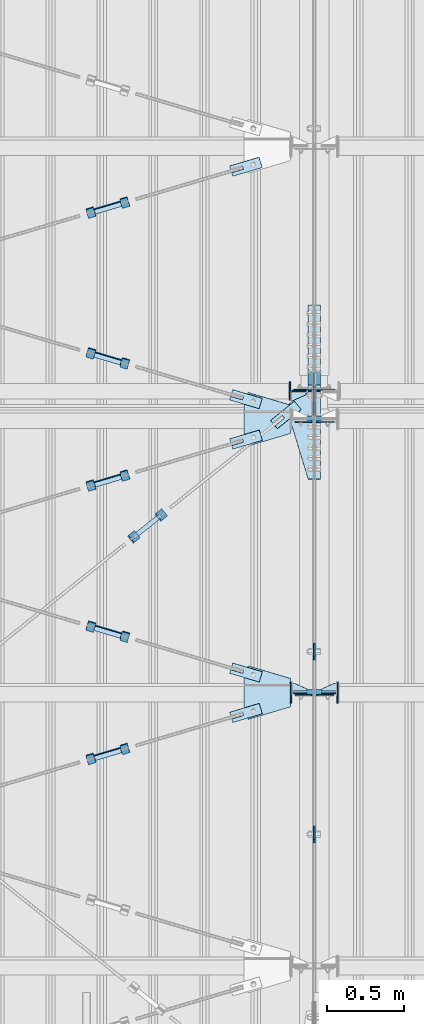
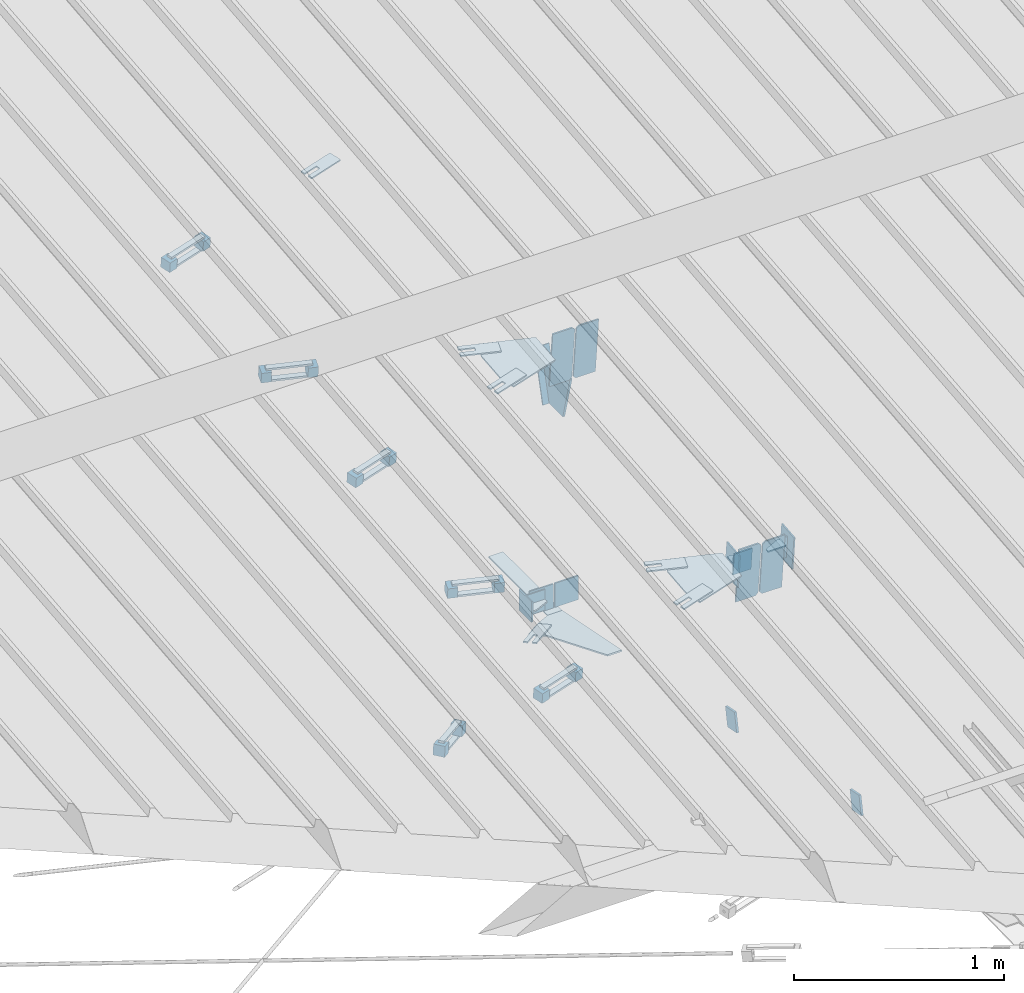
# One storey, part 113 of 709: 53 plates, 5 openings, 20 elements without a shape of their own.
"""IFC4 building model written with IfcOpenShell, lengths in millimetres."""

from ifc_helpers import new_model, si_unit, direction, frame, origin_with_axes, place, context, subcontext, project, spatial, line, indexed_curve, outline, extrude, material, element, aggregate, save


model = new_model("IFC4")

# Units and contexts
model_context = context("Model", 3, precision=0.2, world=origin_with_axes(), true_north=direction((0.0, 1.0)))
body_context = subcontext(model_context, "Body", "Model", "MODEL_VIEW")
ifc_project = project(units=[si_unit("LENGTHUNIT", "METRE", prefix="MILLI"), si_unit("AREAUNIT", "SQUARE_METRE"), si_unit("VOLUMEUNIT", "CUBIC_METRE"), si_unit("MASSUNIT", "GRAM", prefix="KILO"), si_unit("TIMEUNIT", "SECOND"), si_unit("PLANEANGLEUNIT", "RADIAN"), si_unit("SOLIDANGLEUNIT", "STERADIAN"), si_unit("THERMODYNAMICTEMPERATUREUNIT", "DEGREE_CELSIUS"), si_unit("LUMINOUSINTENSITYUNIT", "LUMEN")], contexts=[model_context])

# Site, building, storey
site_placement = place(None, origin_with_axes())
site = spatial("IfcSite", under=ifc_project, at=site_placement, CompositionType="ELEMENT")
building_placement = place(site_placement, origin_with_axes())
building = spatial("IfcBuilding", under=site, at=building_placement, Name="Undefined", CompositionType="ELEMENT")
storey_placement = place(building_placement, origin_with_axes())
storey = spatial("IfcBuildingStorey", under=building, at=storey_placement, Name="Undefined", CompositionType="ELEMENT", Elevation=0.0)

# Assembly, plates
assembly_1_placement = place(storey_placement, frame((10000.0, 346.0, 7089.70002), z_axis=(1.0, 0.0, 0.0), x_axis=(0.0, 0.9950371902, 0.099503719)))
assembly_1 = element("IfcElementAssembly", 1, at=assembly_1_placement, inside=storey)
ifc_material_1 = material(Name="C355-6", Category="STEEL")
plate_1_placement = place(assembly_1_placement, frame((5220.02987, -437.93487, 0.0), z_axis=(0.0, 0.0, -1.0), x_axis=(-0.1614213634, 0.9868855777, 0.0)))
plate_1 = element("IfcPlate", 2, at=plate_1_placement, material=ifc_material_1, ObjectType="442", context=body_context, shape_type="SolidModel", body=[
    extrude(outline(indexed_curve([(0.0, 0.0), (270.19115, 0.0), (225.20717, 275.01958), (-33.64648, 125.57036)], segments=[line(1, 2, 3, 4, 1)])), frame((0.0, 0.0, 6.0), z_axis=(0.0, 0.0, 1.0), x_axis=(1.0, 0.0, 0.0)), (0.0, 0.0, -1.0), 12.0),
])
plate_2_placement = place(assembly_1_placement, frame((5458.83099, -172.70172, -40.0), z_axis=(-0.9353786626, 0.3536477874, 0.0), x_axis=(-0.3536477874, -0.9353786626, 0.0)))
plate_2 = element("IfcPlate", 3, at=plate_2_placement, material=ifc_material_1, ObjectType="443", context=body_context, shape_type="SolidModel", body=[
    extrude(outline(indexed_curve([(0.0, 0.0), (298.89845, 0.0), (298.89845, 80.0), (0.0, 80.0)], segments=[line(1, 2, 3, 4, 1)])), frame((0.0, 0.0, 4.0), z_axis=(0.0, 0.0, 1.0), x_axis=(1.0, 0.0, 0.0)), (0.0, 0.0, -1.0), 8.0),
])
plate_3_placement = place(assembly_1_placement, frame((5169.0059, 163.0, -127.0), z_axis=(1.0, 0.0, 0.0), x_axis=(0.0, 0.0, 1.0)))
plate_3 = element("IfcPlate", 4, at=plate_3_placement, material=ifc_material_1, ObjectType="585", context=body_context, shape_type="SolidModel", body=[
    extrude(outline(indexed_curve([(0.0, 0.0), (108.0, 0.0), (123.0, 15.0), (123.0, 311.0), (108.0, 326.0), (0.0, 326.0)], segments=[line(1, 2, 3, 4, 5, 6, 1)])), frame((0.0, 0.0, 4.0), z_axis=(0.0, 0.0, 1.0), x_axis=(1.0, 0.0, 0.0)), (0.0, 0.0, -1.0), 8.0),
])
plate_4_placement = place(assembly_1_placement, frame((3383.44474, 163.0, 127.0), z_axis=(-1.0, 0.0, 0.0), x_axis=(0.0, 0.0, -1.0)))
plate_4 = element("IfcPlate", 5, at=plate_4_placement, material=ifc_material_1, ObjectType="585", context=body_context, shape_type="SolidModel", body=[
    extrude(outline(indexed_curve([(0.0, 0.0), (108.0, 0.0), (123.0, 15.0), (123.0, 311.0), (108.0, 326.0), (0.0, 326.0)], segments=[line(1, 2, 3, 4, 5, 6, 1)])), frame((0.0, 0.0, 4.0), z_axis=(0.0, 0.0, 1.0), x_axis=(1.0, 0.0, 0.0)), (0.0, 0.0, -1.0), 8.0),
])
plate_5_placement = place(assembly_1_placement, frame((3383.44474, 163.0, -127.0), z_axis=(1.0, 0.0, 0.0), x_axis=(0.0, 0.0, 1.0)))
plate_5 = element("IfcPlate", 6, at=plate_5_placement, material=ifc_material_1, ObjectType="585", context=body_context, shape_type="SolidModel", body=[
    extrude(outline(indexed_curve([(0.0, 0.0), (108.0, 0.0), (123.0, 15.0), (123.0, 311.0), (108.0, 326.0), (0.0, 326.0)], segments=[line(1, 2, 3, 4, 5, 6, 1)])), frame((0.0, 0.0, 4.0), z_axis=(0.0, 0.0, 1.0), x_axis=(1.0, 0.0, 0.0)), (0.0, 0.0, -1.0), 8.0),
])
plate_6_placement = place(assembly_1_placement, frame((5169.0059, 163.0, 127.0), z_axis=(-1.0, 0.0, 0.0), x_axis=(0.0, 0.0, -1.0)))
plate_6 = element("IfcPlate", 7, at=plate_6_placement, material=ifc_material_1, ObjectType="585", context=body_context, shape_type="SolidModel", body=[
    extrude(outline(indexed_curve([(0.0, 0.0), (108.0, 0.0), (123.0, 15.0), (123.0, 311.0), (108.0, 326.0), (0.0, 326.0)], segments=[line(1, 2, 3, 4, 5, 6, 1)])), frame((0.0, 0.0, 4.0), z_axis=(0.0, 0.0, 1.0), x_axis=(1.0, 0.0, 0.0)), (0.0, 0.0, -1.0), 8.0),
])
aggregate(assembly_1, [plate_1, plate_2, plate_3, plate_4, plate_5, plate_6])

# Assembly, plate
assembly_2_placement = place(storey_placement, frame((8916.07962, 4796.2353, 6158.55487), z_axis=(0.625451877, -0.7802627439, 1e-10), x_axis=(0.7742288439, 0.6206151549, -0.124123031)))
assembly_2 = element("IfcElementAssembly", 8, at=assembly_2_placement, inside=storey)
plate_7_placement = place(assembly_2_placement, frame((1061.42526, -5.35577, -34.5878), z_axis=(0.0, -0.9882227647, 0.1530221141), x_axis=(1.0, 0.0, 0.0)))
plate_7 = element("IfcPlate", 9, at=plate_7_placement, material=ifc_material_1, ObjectType="488", context=body_context, shape_type="SolidModel", body=[
    extrude(outline(indexed_curve([(0.0, 0.0), (200.0, 0.0), (200.0, 70.0), (0.0, 70.0), (0.0, 46.0), (80.0, 46.0), (80.0, 24.0), (0.0, 24.0)], segments=[line(1, 2, 3, 4, 5, 6, 7, 8, 1)])), frame((0.0, 0.0, 4.0), z_axis=(0.0, 0.0, 1.0), x_axis=(1.0, 0.0, 0.0)), (0.0, 0.0, -1.0), 8.0),
])
aggregate(assembly_2, [plate_7])

# Assembly, plates
assembly_3_placement = place(storey_placement, frame((9026.78495, 4846.52715, 6174.04872), z_axis=(-0.7742288439, -0.6206151548, 0.1241230313), x_axis=(-0.625451877, 0.780262744, 0.0)))
assembly_3 = element("IfcElementAssembly", 10, at=assembly_3_placement, inside=storey)
ifc_material_2 = material(Name="Steel_Undefined", Category="STEEL")
plate_8_placement = place(assembly_3_placement, frame((15.0, -6.0, 230.0), z_axis=(0.0, 1.0, 0.0), x_axis=(1.0, 0.0, 0.0)))
plate_8 = element("IfcPlate", 11, at=plate_8_placement, material=ifc_material_2, ObjectType="484", context=body_context, shape_type="SolidModel", body=[
    extrude(outline(indexed_curve([(0.0, 0.0), (30.0, 0.0), (30.0, 230.0), (0.0, 230.0)], segments=[line(1, 2, 3, 4, 1)])), frame((0.0, 0.0, 6.0), z_axis=(0.0, 0.0, 1.0), x_axis=(1.0, 0.0, 0.0)), (0.0, 0.0, -1.0), 12.0),
])
plate_9_placement = place(assembly_3_placement, frame((15.0, 66.0, 230.0), z_axis=(0.0, 1.0, 0.0), x_axis=(1.0, 0.0, 0.0)))
plate_9 = element("IfcPlate", 12, at=plate_9_placement, material=ifc_material_2, ObjectType="484", context=body_context, shape_type="SolidModel", body=[
    extrude(outline(indexed_curve([(0.0, 0.0), (30.0, 0.0), (30.0, 230.0), (0.0, 230.0)], segments=[line(1, 2, 3, 4, 1)])), frame((0.0, 0.0, 6.0), z_axis=(0.0, 0.0, 1.0), x_axis=(1.0, 0.0, 0.0)), (0.0, 0.0, -1.0), 12.0),
])
plate_10_placement = place(assembly_3_placement, frame((0.0, 0.0, 230.0), z_axis=(0.0, 0.0, 1.0), x_axis=(1.0, 0.0, 0.0)))
plate_10 = element("IfcPlate", 13, at=plate_10_placement, material=ifc_material_2, ObjectType="483", context=body_context, shape_type="SolidModel", body=[
    extrude(outline(indexed_curve([(0.0, 0.0), (60.0, 0.0), (60.0, 60.0), (0.0, 60.0)], segments=[line(1, 2, 3, 4, 1)])), frame((0.0, 0.0, 25.0), z_axis=(0.0, 0.0, 1.0), x_axis=(1.0, 0.0, 0.0)), (0.0, 0.0, -1.0), 50.0),
])
plate_11_placement = place(assembly_3_placement, origin_with_axes())
plate_11 = element("IfcPlate", 14, at=plate_11_placement, material=ifc_material_2, ObjectType="482", context=body_context, shape_type="SolidModel", body=[
    extrude(outline(indexed_curve([(0.0, 0.0), (60.0, 0.0), (60.0, 60.0), (0.0, 60.0)], segments=[line(1, 2, 3, 4, 1)])), frame((0.0, 0.0, 25.0), z_axis=(0.0, 0.0, 1.0), x_axis=(1.0, 0.0, 0.0)), (0.0, 0.0, -1.0), 50.0),
])
aggregate(assembly_3, [plate_8, plate_9, plate_10, plate_11])

assembly_4_placement = place(storey_placement, frame((10000.0, 5668.61344, 5980.00002), z_axis=(1.0, 0.0, 0.0), x_axis=(0.0, 1.0, 0.0)))
assembly_4 = element("IfcElementAssembly", 15, at=assembly_4_placement, inside=storey)
plate_12_placement = place(assembly_4_placement, frame((12.38656, 164.3, 134.0), z_axis=(-1.0, 0.0, 0.0), x_axis=(0.0, 0.0, -1.0)))
plate_12 = element("IfcPlate", 16, at=plate_12_placement, material=ifc_material_1, ObjectType="558", context=body_context, shape_type="SolidModel", body=[
    extrude(outline(indexed_curve([(0.0, 0.0), (130.0, 0.0), (130.0, 140.0), (0.0, 140.0)], segments=[line(1, 2, 3, 4, 1)])), frame((0.0, 0.0, 4.0), z_axis=(0.0, 0.0, 1.0), x_axis=(1.0, 0.0, 0.0)), (0.0, 0.0, -1.0), 8.0),
])
plate_13_placement = place(assembly_4_placement, frame((12.38656, 164.3, -134.0), z_axis=(1.0, 0.0, 0.0), x_axis=(0.0, 0.0, 1.0)))
plate_13 = element("IfcPlate", 17, at=plate_13_placement, material=ifc_material_1, ObjectType="558", context=body_context, shape_type="SolidModel", body=[
    extrude(outline(indexed_curve([(0.0, 0.0), (130.0, 0.0), (130.0, 140.0), (0.0, 140.0)], segments=[line(1, 2, 3, 4, 1)])), frame((0.0, 0.0, 4.0), z_axis=(0.0, 0.0, 1.0), x_axis=(1.0, 0.0, 0.0)), (0.0, 0.0, -1.0), 8.0),
])
plate_14_placement = place(assembly_4_placement, frame((-0.78446, -3.92232, 40.0), z_axis=(0.1961161349, 0.9805806757, 0.0), x_axis=(0.0, 0.0, -1.0)))
plate_14 = element("IfcPlate", 18, at=plate_14_placement, material=ifc_material_1, ObjectType="487", context=body_context, shape_type="SolidModel", body=[
    extrude(outline(indexed_curve([(0.0, 0.0), (80.0, 0.0), (175.76932, 57.25102), (253.1922, 120.5416), (196.23068, 190.22219), (80.0, 579.50696), (0.0, 579.50696)], segments=[line(1, 2, 3, 4, 5, 6, 7, 1)])), frame((0.0, 0.0, 4.0), z_axis=(0.0, 0.0, 1.0), x_axis=(1.0, 0.0, 0.0)), (0.0, 0.0, -1.0), 8.0),
])
plate_15_placement = place(assembly_4_placement, frame((564.38656, -4.0, -40.0), z_axis=(0.0, 1.0, 0.0), x_axis=(-1.0, 0.0, 0.0)))
plate_15 = element("IfcPlate", 19, at=plate_15_placement, material=ifc_material_1, ObjectType="446", context=body_context, shape_type="SolidModel", body=[
    extrude(outline(indexed_curve([(0.0, 0.0), (564.38656, 0.0), (564.38656, 80.0), (0.0, 80.0)], segments=[line(1, 2, 3, 4, 1)])), frame((0.0, 0.0, 4.0), z_axis=(0.0, 0.0, 1.0), x_axis=(1.0, 0.0, 0.0)), (0.0, 0.0, -1.0), 8.0),
])
aggregate(assembly_4, [plate_12, plate_13, plate_14, plate_15])

# Assembly, plate
assembly_5_placement = place(storey_placement, frame((10000.0, 2758.46612, 6684.40595), z_axis=(-1.0, 0.0, 0.0), x_axis=(0.0, 0.9805806757, -0.1961161349)))
assembly_5 = element("IfcElementAssembly", 20, at=assembly_5_placement, inside=storey)
plate_16_placement = place(assembly_5_placement, origin_with_axes())
plate_16 = element("IfcPlate", 21, at=plate_16_placement, material=ifc_material_1, ObjectType="491", context=body_context, shape_type="SolidModel", body=[
    extrude(outline(indexed_curve([(0.0, 0.0), (90.0, 0.0), (90.0, 110.0), (0.0, 110.0)], segments=[line(1, 2, 3, 4, 1)])), frame((0.0, 0.0, 6.0), z_axis=(0.0, 0.0, 1.0), x_axis=(1.0, 0.0, 0.0)), (0.0, 0.0, -1.0), 12.0),
])
aggregate(assembly_5, [plate_16])

assembly_6_placement = place(storey_placement, frame((10000.0, 3946.08299, 6446.88258), z_axis=(-1.0, 0.0, 0.0), x_axis=(0.0, 0.9805806757, -0.1961161349)))
assembly_6 = element("IfcElementAssembly", 22, at=assembly_6_placement, inside=storey)
plate_17_placement = place(assembly_6_placement, origin_with_axes())
plate_17 = element("IfcPlate", 23, at=plate_17_placement, material=ifc_material_1, ObjectType="491", context=body_context, shape_type="SolidModel", body=[
    extrude(outline(indexed_curve([(0.0, 0.0), (90.0, 0.0), (90.0, 110.0), (0.0, 110.0)], segments=[line(1, 2, 3, 4, 1)])), frame((0.0, 0.0, 6.0), z_axis=(0.0, 0.0, 1.0), x_axis=(1.0, 0.0, 0.0)), (0.0, 0.0, -1.0), 12.0),
])
aggregate(assembly_6, [plate_17])

# Assembly, plates
assembly_7_placement = place(storey_placement, frame((4000.0, 5673.0, 6074.30002), z_axis=(0.0, -1.0, 0.0), x_axis=(1.0, 0.0, 0.0)))
assembly_7 = element("IfcElementAssembly", 24, at=assembly_7_placement, inside=storey)
plate_18_placement = place(assembly_7_placement, frame((5946.0, 0.0, 60.0), z_axis=(0.0, 1.0, 0.0), x_axis=(0.0, 0.0, -1.0)))
plate_18 = element("IfcPlate", 25, at=plate_18_placement, material=ifc_material_1, ObjectType="561", context=body_context, shape_type="SolidModel", body=[
    extrude(outline(indexed_curve([(0.0, 80.0), (36.0, 0.0), (56.0, 0.0), (56.0, 90.0), (46.0, 100.0), (0.0, 100.0)], segments=[line(1, 2, 3, 4, 5, 6, 1)])), frame((0.0, 0.0, 4.0), z_axis=(0.0, 0.0, 1.0), x_axis=(1.0, 0.0, 0.0)), (0.0, 0.0, -1.0), 8.0),
])
plate_19_placement = place(assembly_7_placement, frame((5842.0, 60.0, -60.0), z_axis=(1.0, 0.0, 0.0), x_axis=(0.0, 0.0, 1.0)))
plate_19 = element("IfcPlate", 26, at=plate_19_placement, material=ifc_material_1, ObjectType="559", context=body_context, shape_type="SolidModel", body=[
    extrude(outline(indexed_curve([(0.0, 0.0), (120.0, 0.0), (120.0, 120.0), (0.0, 120.0)], segments=[line(1, 2, 3, 4, 1)])), frame((0.0, 0.0, 4.0), z_axis=(0.0, 0.0, 1.0), x_axis=(1.0, 0.0, 0.0)), (0.0, 0.0, -1.0), 8.0),
])
plate_20_placement = place(assembly_7_placement, frame((5946.0, 60.0, 0.0), z_axis=(0.0, 0.0, -1.0), x_axis=(0.0, -1.0, 0.0)))
plate_20 = element("IfcPlate", 27, at=plate_20_placement, material=ifc_material_1, ObjectType="560", context=body_context, shape_type="SolidModel", body=[
    extrude(outline(indexed_curve([(0.0, 0.0), (120.0, 0.0), (120.0, 100.0), (0.0, 100.0)], segments=[line(1, 2, 3, 4, 1)])), frame((0.0, 0.0, 4.0), z_axis=(0.0, 0.0, 1.0), x_axis=(1.0, 0.0, 0.0)), (0.0, 0.0, -1.0), 8.0),
])
aggregate(assembly_7, [plate_18, plate_19, plate_20])

# Assembly, plate, voiding feature
assembly_8_placement = place(storey_placement, frame((8658.15773, 3315.21204, 7468.02522), z_axis=(0.2852311229, -0.9537021177, -0.0953702118), x_axis=(0.9584587662, 0.2838155751, 0.028381558)))
assembly_8 = element("IfcElementAssembly", 28, at=assembly_8_placement, inside=storey)
plate_21_placement = place(assembly_8_placement, frame((1036.9749, 0.0, 35.0), z_axis=(0.0, 1.0, 0.0), x_axis=(0.0, 0.0, -1.0)))
plate_21 = element("IfcPlate", 29, at=plate_21_placement, material=ifc_material_1, ObjectType="574", context=body_context, shape_type="SolidModel", body=[
    extrude(outline(indexed_curve([(0.0, 0.0), (70.0, 0.0), (70.0, 200.0), (0.0, 200.0)], segments=[line(1, 2, 3, 4, 1)])), frame((0.0, 0.0, 4.0), z_axis=(0.0, 0.0, 1.0), x_axis=(1.0, 0.0, 0.0)), (0.0, 0.0, -1.0), 8.0),
])
voiding_feature_1_placement = place(plate_21_placement, frame((24.0, 120.0, 0.0), z_axis=(0.0, 0.0, 1.0), x_axis=(1.0, 0.0, 0.0)))
element("IfcVoidingFeature", 30, at=voiding_feature_1_placement, cuts=plate_21, Name="PLATE", PredefinedType="HOLE", context=body_context, shape_type="SolidModel", body=[
    extrude(outline(indexed_curve([(0.0, 0.0), (22.0, 0.0), (22.0, 85.0), (0.0, 85.0)], segments=[line(1, 2, 3, 4, 1)])), frame((0.0, 0.0, 6.5), z_axis=(0.0, 0.0, 1.0), x_axis=(1.0, 0.0, 0.0)), (0.0, 0.0, -1.0), 13.0),
])
aggregate(assembly_8, [plate_21])

# Assembly, plates
assembly_9_placement = place(storey_placement, frame((8776.93742, 3316.25466, 7498.27911), z_axis=(-0.9584587662, -0.2838155751, -0.0283815575), x_axis=(-0.2852311229, 0.9537021176, 0.095370212)))
assembly_9 = element("IfcElementAssembly", 31, at=assembly_9_placement, inside=storey)
plate_22_placement = place(assembly_9_placement, frame((15.0, 66.0, 230.0), z_axis=(0.0, 1.0, 0.0), x_axis=(1.0, 0.0, 0.0)))
plate_22 = element("IfcPlate", 32, at=plate_22_placement, material=ifc_material_2, ObjectType="484", context=body_context, shape_type="SolidModel", body=[
    extrude(outline(indexed_curve([(0.0, 0.0), (30.0, 0.0), (30.0, 230.0), (0.0, 230.0)], segments=[line(1, 2, 3, 4, 1)])), frame((0.0, 0.0, 6.0), z_axis=(0.0, 0.0, 1.0), x_axis=(1.0, 0.0, 0.0)), (0.0, 0.0, -1.0), 12.0),
])
plate_23_placement = place(assembly_9_placement, frame((0.0, 0.0, 230.0), z_axis=(0.0, 0.0, 1.0), x_axis=(1.0, 0.0, 0.0)))
plate_23 = element("IfcPlate", 33, at=plate_23_placement, material=ifc_material_2, ObjectType="483", context=body_context, shape_type="SolidModel", body=[
    extrude(outline(indexed_curve([(0.0, 0.0), (60.0, 0.0), (60.0, 60.0), (0.0, 60.0)], segments=[line(1, 2, 3, 4, 1)])), frame((0.0, 0.0, 25.0), z_axis=(0.0, 0.0, 1.0), x_axis=(1.0, 0.0, 0.0)), (0.0, 0.0, -1.0), 50.0),
])
plate_24_placement = place(assembly_9_placement, frame((15.0, -6.0, 230.0), z_axis=(0.0, 1.0, 0.0), x_axis=(1.0, 0.0, 0.0)))
plate_24 = element("IfcPlate", 34, at=plate_24_placement, material=ifc_material_2, ObjectType="484", context=body_context, shape_type="SolidModel", body=[
    extrude(outline(indexed_curve([(0.0, 0.0), (30.0, 0.0), (30.0, 230.0), (0.0, 230.0)], segments=[line(1, 2, 3, 4, 1)])), frame((0.0, 0.0, 6.0), z_axis=(0.0, 0.0, 1.0), x_axis=(1.0, 0.0, 0.0)), (0.0, 0.0, -1.0), 12.0),
])
plate_25_placement = place(assembly_9_placement, origin_with_axes())
plate_25 = element("IfcPlate", 35, at=plate_25_placement, material=ifc_material_2, ObjectType="482", context=body_context, shape_type="SolidModel", body=[
    extrude(outline(indexed_curve([(0.0, 0.0), (60.0, 0.0), (60.0, 60.0), (0.0, 60.0)], segments=[line(1, 2, 3, 4, 1)])), frame((0.0, 0.0, 25.0), z_axis=(0.0, 0.0, 1.0), x_axis=(1.0, 0.0, 0.0)), (0.0, 0.0, -1.0), 50.0),
])
aggregate(assembly_9, [plate_22, plate_23, plate_24, plate_25])

# Assembly, plate, voiding feature
assembly_10_placement = place(storey_placement, frame((8658.15773, 5091.91179, 7645.6952), z_axis=(0.2852311229, -0.9537021177, -0.0953702118), x_axis=(0.9584587662, 0.2838155751, 0.028381558)))
assembly_10 = element("IfcElementAssembly", 36, at=assembly_10_placement, inside=storey)
plate_26_placement = place(assembly_10_placement, frame((1036.9749, 0.0, 35.0), z_axis=(0.0, 1.0, 0.0), x_axis=(0.0, 0.0, -1.0)))
plate_26 = element("IfcPlate", 37, at=plate_26_placement, material=ifc_material_1, ObjectType="574", context=body_context, shape_type="SolidModel", body=[
    extrude(outline(indexed_curve([(0.0, 0.0), (70.0, 0.0), (70.0, 200.0), (0.0, 200.0)], segments=[line(1, 2, 3, 4, 1)])), frame((0.0, 0.0, 4.0), z_axis=(0.0, 0.0, 1.0), x_axis=(1.0, 0.0, 0.0)), (0.0, 0.0, -1.0), 8.0),
])
voiding_feature_2_placement = place(plate_26_placement, frame((24.0, 120.0, 0.0), z_axis=(0.0, 0.0, 1.0), x_axis=(1.0, 0.0, 0.0)))
element("IfcVoidingFeature", 38, at=voiding_feature_2_placement, cuts=plate_26, Name="PLATE", PredefinedType="HOLE", context=body_context, shape_type="SolidModel", body=[
    extrude(outline(indexed_curve([(0.0, 0.0), (22.0, 0.0), (22.0, 85.0), (0.0, 85.0)], segments=[line(1, 2, 3, 4, 1)])), frame((0.0, 0.0, 6.5), z_axis=(0.0, 0.0, 1.0), x_axis=(1.0, 0.0, 0.0)), (0.0, 0.0, -1.0), 13.0),
])
aggregate(assembly_10, [plate_26])

# Assembly, plates
assembly_11_placement = place(storey_placement, frame((8776.93742, 5092.95441, 7675.94908), z_axis=(-0.9584587662, -0.2838155751, -0.0283815575), x_axis=(-0.2852311229, 0.9537021176, 0.095370212)))
assembly_11 = element("IfcElementAssembly", 39, at=assembly_11_placement, inside=storey)
plate_27_placement = place(assembly_11_placement, origin_with_axes())
plate_27 = element("IfcPlate", 40, at=plate_27_placement, material=ifc_material_2, ObjectType="482", context=body_context, shape_type="SolidModel", body=[
    extrude(outline(indexed_curve([(0.0, 0.0), (60.0, 0.0), (60.0, 60.0), (0.0, 60.0)], segments=[line(1, 2, 3, 4, 1)])), frame((0.0, 0.0, 25.0), z_axis=(0.0, 0.0, 1.0), x_axis=(1.0, 0.0, 0.0)), (0.0, 0.0, -1.0), 50.0),
])
plate_28_placement = place(assembly_11_placement, frame((15.0, 66.0, 230.0), z_axis=(0.0, 1.0, 0.0), x_axis=(1.0, 0.0, 0.0)))
plate_28 = element("IfcPlate", 41, at=plate_28_placement, material=ifc_material_2, ObjectType="484", context=body_context, shape_type="SolidModel", body=[
    extrude(outline(indexed_curve([(0.0, 0.0), (30.0, 0.0), (30.0, 230.0), (0.0, 230.0)], segments=[line(1, 2, 3, 4, 1)])), frame((0.0, 0.0, 6.0), z_axis=(0.0, 0.0, 1.0), x_axis=(1.0, 0.0, 0.0)), (0.0, 0.0, -1.0), 12.0),
])
plate_29_placement = place(assembly_11_placement, frame((15.0, -6.0, 230.0), z_axis=(0.0, 1.0, 0.0), x_axis=(1.0, 0.0, 0.0)))
plate_29 = element("IfcPlate", 42, at=plate_29_placement, material=ifc_material_2, ObjectType="484", context=body_context, shape_type="SolidModel", body=[
    extrude(outline(indexed_curve([(0.0, 0.0), (30.0, 0.0), (30.0, 230.0), (0.0, 230.0)], segments=[line(1, 2, 3, 4, 1)])), frame((0.0, 0.0, 6.0), z_axis=(0.0, 0.0, 1.0), x_axis=(1.0, 0.0, 0.0)), (0.0, 0.0, -1.0), 12.0),
])
plate_30_placement = place(assembly_11_placement, frame((0.0, 0.0, 230.0), z_axis=(0.0, 0.0, 1.0), x_axis=(1.0, 0.0, 0.0)))
plate_30 = element("IfcPlate", 43, at=plate_30_placement, material=ifc_material_2, ObjectType="483", context=body_context, shape_type="SolidModel", body=[
    extrude(outline(indexed_curve([(0.0, 0.0), (60.0, 0.0), (60.0, 60.0), (0.0, 60.0)], segments=[line(1, 2, 3, 4, 1)])), frame((0.0, 0.0, 25.0), z_axis=(0.0, 0.0, 1.0), x_axis=(1.0, 0.0, 0.0)), (0.0, 0.0, -1.0), 50.0),
])
aggregate(assembly_11, [plate_27, plate_28, plate_29, plate_30])

# Assembly, plate, voiding feature
assembly_12_placement = place(storey_placement, frame((8658.15773, 4109.89565, 7547.49358), z_axis=(-0.2852311229, -0.9537021177, -0.0953702118), x_axis=(0.9584587662, -0.2838155751, -0.028381558)))
assembly_12 = element("IfcElementAssembly", 44, at=assembly_12_placement, inside=storey)
plate_31_placement = place(assembly_12_placement, frame((1036.9749, 0.0, 35.0), z_axis=(0.0, 1.0, 0.0), x_axis=(0.0, 0.0, -1.0)))
plate_31 = element("IfcPlate", 45, at=plate_31_placement, material=ifc_material_1, ObjectType="574", context=body_context, shape_type="SolidModel", body=[
    extrude(outline(indexed_curve([(0.0, 0.0), (70.0, 0.0), (70.0, 200.0), (0.0, 200.0)], segments=[line(1, 2, 3, 4, 1)])), frame((0.0, 0.0, 4.0), z_axis=(0.0, 0.0, 1.0), x_axis=(1.0, 0.0, 0.0)), (0.0, 0.0, -1.0), 8.0),
])
voiding_feature_3_placement = place(plate_31_placement, frame((24.0, 120.0, 0.0), z_axis=(0.0, 0.0, 1.0), x_axis=(1.0, 0.0, 0.0)))
element("IfcVoidingFeature", 46, at=voiding_feature_3_placement, cuts=plate_31, Name="PLATE", PredefinedType="HOLE", context=body_context, shape_type="SolidModel", body=[
    extrude(outline(indexed_curve([(0.0, 0.0), (22.0, 0.0), (22.0, 85.0), (0.0, 85.0)], segments=[line(1, 2, 3, 4, 1)])), frame((0.0, 0.0, 6.5), z_axis=(0.0, 0.0, 1.0), x_axis=(1.0, 0.0, 0.0)), (0.0, 0.0, -1.0), 13.0),
])
aggregate(assembly_12, [plate_31])

# Assembly, plates
assembly_13_placement = place(storey_placement, frame((8759.82355, 4045.66069, 7571.21971), z_axis=(-0.9584587662, 0.2838155751, 0.0283815575), x_axis=(0.2852311229, 0.9537021176, 0.095370212)))
assembly_13 = element("IfcElementAssembly", 47, at=assembly_13_placement, inside=storey)
plate_32_placement = place(assembly_13_placement, frame((0.0, 0.0, 230.0), z_axis=(0.0, 0.0, 1.0), x_axis=(1.0, 0.0, 0.0)))
plate_32 = element("IfcPlate", 48, at=plate_32_placement, material=ifc_material_2, ObjectType="483", context=body_context, shape_type="SolidModel", body=[
    extrude(outline(indexed_curve([(0.0, 0.0), (60.0, 0.0), (60.0, 60.0), (0.0, 60.0)], segments=[line(1, 2, 3, 4, 1)])), frame((0.0, 0.0, 25.0), z_axis=(0.0, 0.0, 1.0), x_axis=(1.0, 0.0, 0.0)), (0.0, 0.0, -1.0), 50.0),
])
plate_33_placement = place(assembly_13_placement, frame((15.0, 66.0, 230.0), z_axis=(0.0, 1.0, 0.0), x_axis=(1.0, 0.0, 0.0)))
plate_33 = element("IfcPlate", 49, at=plate_33_placement, material=ifc_material_2, ObjectType="484", context=body_context, shape_type="SolidModel", body=[
    extrude(outline(indexed_curve([(0.0, 0.0), (30.0, 0.0), (30.0, 230.0), (0.0, 230.0)], segments=[line(1, 2, 3, 4, 1)])), frame((0.0, 0.0, 6.0), z_axis=(0.0, 0.0, 1.0), x_axis=(1.0, 0.0, 0.0)), (0.0, 0.0, -1.0), 12.0),
])
plate_34_placement = place(assembly_13_placement, frame((15.0, -6.0, 230.0), z_axis=(0.0, 1.0, 0.0), x_axis=(1.0, 0.0, 0.0)))
plate_34 = element("IfcPlate", 50, at=plate_34_placement, material=ifc_material_2, ObjectType="484", context=body_context, shape_type="SolidModel", body=[
    extrude(outline(indexed_curve([(0.0, 0.0), (30.0, 0.0), (30.0, 230.0), (0.0, 230.0)], segments=[line(1, 2, 3, 4, 1)])), frame((0.0, 0.0, 6.0), z_axis=(0.0, 0.0, 1.0), x_axis=(1.0, 0.0, 0.0)), (0.0, 0.0, -1.0), 12.0),
])
plate_35_placement = place(assembly_13_placement, origin_with_axes())
plate_35 = element("IfcPlate", 51, at=plate_35_placement, material=ifc_material_2, ObjectType="482", context=body_context, shape_type="SolidModel", body=[
    extrude(outline(indexed_curve([(0.0, 0.0), (60.0, 0.0), (60.0, 60.0), (0.0, 60.0)], segments=[line(1, 2, 3, 4, 1)])), frame((0.0, 0.0, 25.0), z_axis=(0.0, 0.0, 1.0), x_axis=(1.0, 0.0, 0.0)), (0.0, 0.0, -1.0), 50.0),
])
aggregate(assembly_13, [plate_32, plate_33, plate_34, plate_35])

# Assembly, plate, voiding feature
assembly_14_placement = place(storey_placement, frame((8657.949, 6865.91062, 7823.09508), z_axis=(0.2847296511, -0.9538504697, -0.095385047), x_axis=(0.9586078582, 0.2833165921, 0.028331659)))
assembly_14 = element("IfcElementAssembly", 52, at=assembly_14_placement, inside=storey)
plate_36_placement = place(assembly_14_placement, frame((1036.31721, 0.0, 35.0), z_axis=(0.0, 1.0, 0.0), x_axis=(0.0, 0.0, -1.0)))
plate_36 = element("IfcPlate", 53, at=plate_36_placement, material=ifc_material_1, ObjectType="574", context=body_context, shape_type="SolidModel", body=[
    extrude(outline(indexed_curve([(0.0, 0.0), (70.0, 0.0), (70.0, 200.0), (0.0, 200.0)], segments=[line(1, 2, 3, 4, 1)])), frame((0.0, 0.0, 4.0), z_axis=(0.0, 0.0, 1.0), x_axis=(1.0, 0.0, 0.0)), (0.0, 0.0, -1.0), 8.0),
])
voiding_feature_4_placement = place(plate_36_placement, frame((24.0, 120.0, 0.0), z_axis=(0.0, 0.0, 1.0), x_axis=(1.0, 0.0, 0.0)))
element("IfcVoidingFeature", 54, at=voiding_feature_4_placement, cuts=plate_36, Name="PLATE", PredefinedType="HOLE", context=body_context, shape_type="SolidModel", body=[
    extrude(outline(indexed_curve([(0.0, 0.0), (22.0, 0.0), (22.0, 85.0), (0.0, 85.0)], segments=[line(1, 2, 3, 4, 1)])), frame((0.0, 0.0, 6.5), z_axis=(0.0, 0.0, 1.0), x_axis=(1.0, 0.0, 0.0)), (0.0, 0.0, -1.0), 13.0),
])
aggregate(assembly_14, [plate_36])

# Assembly, plates
assembly_15_placement = place(storey_placement, frame((8776.73079, 6866.8914, 7853.34278), z_axis=(-0.9586078582, -0.2833165918, -0.0283316592), x_axis=(-0.2847296509, 0.9538504698, 0.095385047)))
assembly_15 = element("IfcElementAssembly", 55, at=assembly_15_placement, inside=storey)
plate_37_placement = place(assembly_15_placement, origin_with_axes())
plate_37 = element("IfcPlate", 56, at=plate_37_placement, material=ifc_material_2, ObjectType="482", context=body_context, shape_type="SolidModel", body=[
    extrude(outline(indexed_curve([(0.0, 0.0), (60.0, 0.0), (60.0, 60.0), (0.0, 60.0)], segments=[line(1, 2, 3, 4, 1)])), frame((0.0, 0.0, 25.0), z_axis=(0.0, 0.0, 1.0), x_axis=(1.0, 0.0, 0.0)), (0.0, 0.0, -1.0), 50.0),
])
plate_38_placement = place(assembly_15_placement, frame((15.0, -6.0, 230.0), z_axis=(0.0, 1.0, 0.0), x_axis=(1.0, 0.0, 0.0)))
plate_38 = element("IfcPlate", 57, at=plate_38_placement, material=ifc_material_2, ObjectType="484", context=body_context, shape_type="SolidModel", body=[
    extrude(outline(indexed_curve([(0.0, 0.0), (30.0, 0.0), (30.0, 230.0), (0.0, 230.0)], segments=[line(1, 2, 3, 4, 1)])), frame((0.0, 0.0, 6.0), z_axis=(0.0, 0.0, 1.0), x_axis=(1.0, 0.0, 0.0)), (0.0, 0.0, -1.0), 12.0),
])
plate_39_placement = place(assembly_15_placement, frame((15.0, 66.0, 230.0), z_axis=(0.0, 1.0, 0.0), x_axis=(1.0, 0.0, 0.0)))
plate_39 = element("IfcPlate", 58, at=plate_39_placement, material=ifc_material_2, ObjectType="484", context=body_context, shape_type="SolidModel", body=[
    extrude(outline(indexed_curve([(0.0, 0.0), (30.0, 0.0), (30.0, 230.0), (0.0, 230.0)], segments=[line(1, 2, 3, 4, 1)])), frame((0.0, 0.0, 6.0), z_axis=(0.0, 0.0, 1.0), x_axis=(1.0, 0.0, 0.0)), (0.0, 0.0, -1.0), 12.0),
])
plate_40_placement = place(assembly_15_placement, frame((0.0, 0.0, 230.0), z_axis=(0.0, 0.0, 1.0), x_axis=(1.0, 0.0, 0.0)))
plate_40 = element("IfcPlate", 59, at=plate_40_placement, material=ifc_material_2, ObjectType="483", context=body_context, shape_type="SolidModel", body=[
    extrude(outline(indexed_curve([(0.0, 0.0), (60.0, 0.0), (60.0, 60.0), (0.0, 60.0)], segments=[line(1, 2, 3, 4, 1)])), frame((0.0, 0.0, 25.0), z_axis=(0.0, 0.0, 1.0), x_axis=(1.0, 0.0, 0.0)), (0.0, 0.0, -1.0), 50.0),
])
aggregate(assembly_15, [plate_37, plate_38, plate_39, plate_40])

# Assembly, plate, voiding feature
assembly_16_placement = place(storey_placement, frame((8657.949, 5885.89683, 7725.0937), z_axis=(-0.2847296511, -0.9538504697, -0.095385047), x_axis=(0.9586078582, -0.2833165921, -0.028331659)))
assembly_16 = element("IfcElementAssembly", 60, at=assembly_16_placement, inside=storey)
plate_41_placement = place(assembly_16_placement, frame((1036.31721, 0.0, 35.0), z_axis=(0.0, 1.0, 0.0), x_axis=(0.0, 0.0, -1.0)))
plate_41 = element("IfcPlate", 61, at=plate_41_placement, material=ifc_material_1, ObjectType="574", context=body_context, shape_type="SolidModel", body=[
    extrude(outline(indexed_curve([(0.0, 0.0), (70.0, 0.0), (70.0, 200.0), (0.0, 200.0)], segments=[line(1, 2, 3, 4, 1)])), frame((0.0, 0.0, 4.0), z_axis=(0.0, 0.0, 1.0), x_axis=(1.0, 0.0, 0.0)), (0.0, 0.0, -1.0), 8.0),
])
voiding_feature_5_placement = place(plate_41_placement, frame((24.0, 120.0, 0.0), z_axis=(0.0, 0.0, 1.0), x_axis=(1.0, 0.0, 0.0)))
element("IfcVoidingFeature", 62, at=voiding_feature_5_placement, cuts=plate_41, Name="PLATE", PredefinedType="HOLE", context=body_context, shape_type="SolidModel", body=[
    extrude(outline(indexed_curve([(0.0, 0.0), (22.0, 0.0), (22.0, 85.0), (0.0, 85.0)], segments=[line(1, 2, 3, 4, 1)])), frame((0.0, 0.0, 6.5), z_axis=(0.0, 0.0, 1.0), x_axis=(1.0, 0.0, 0.0)), (0.0, 0.0, -1.0), 13.0),
])
aggregate(assembly_16, [plate_41])

# Assembly, plates
assembly_17_placement = place(storey_placement, frame((8759.64701, 5821.71479, 7748.82512), z_axis=(-0.9586078582, 0.2833165918, 0.0283316592), x_axis=(0.2847296509, 0.9538504698, 0.095385047)))
assembly_17 = element("IfcElementAssembly", 63, at=assembly_17_placement, inside=storey)
plate_42_placement = place(assembly_17_placement, frame((15.0, 66.0, 230.0), z_axis=(0.0, 1.0, 0.0), x_axis=(1.0, 0.0, 0.0)))
plate_42 = element("IfcPlate", 64, at=plate_42_placement, material=ifc_material_2, ObjectType="484", context=body_context, shape_type="SolidModel", body=[
    extrude(outline(indexed_curve([(0.0, 0.0), (30.0, 0.0), (30.0, 230.0), (0.0, 230.0)], segments=[line(1, 2, 3, 4, 1)])), frame((0.0, 0.0, 6.0), z_axis=(0.0, 0.0, 1.0), x_axis=(1.0, 0.0, 0.0)), (0.0, 0.0, -1.0), 12.0),
])
plate_43_placement = place(assembly_17_placement, frame((15.0, -6.0, 230.0), z_axis=(0.0, 1.0, 0.0), x_axis=(1.0, 0.0, 0.0)))
plate_43 = element("IfcPlate", 65, at=plate_43_placement, material=ifc_material_2, ObjectType="484", context=body_context, shape_type="SolidModel", body=[
    extrude(outline(indexed_curve([(0.0, 0.0), (30.0, 0.0), (30.0, 230.0), (0.0, 230.0)], segments=[line(1, 2, 3, 4, 1)])), frame((0.0, 0.0, 6.0), z_axis=(0.0, 0.0, 1.0), x_axis=(1.0, 0.0, 0.0)), (0.0, 0.0, -1.0), 12.0),
])
plate_44_placement = place(assembly_17_placement, frame((0.0, 0.0, 230.0), z_axis=(0.0, 0.0, 1.0), x_axis=(1.0, 0.0, 0.0)))
plate_44 = element("IfcPlate", 66, at=plate_44_placement, material=ifc_material_2, ObjectType="483", context=body_context, shape_type="SolidModel", body=[
    extrude(outline(indexed_curve([(0.0, 0.0), (60.0, 0.0), (60.0, 60.0), (0.0, 60.0)], segments=[line(1, 2, 3, 4, 1)])), frame((0.0, 0.0, 25.0), z_axis=(0.0, 0.0, 1.0), x_axis=(1.0, 0.0, 0.0)), (0.0, 0.0, -1.0), 50.0),
])
plate_45_placement = place(assembly_17_placement, origin_with_axes())
plate_45 = element("IfcPlate", 67, at=plate_45_placement, material=ifc_material_2, ObjectType="482", context=body_context, shape_type="SolidModel", body=[
    extrude(outline(indexed_curve([(0.0, 0.0), (60.0, 0.0), (60.0, 60.0), (0.0, 60.0)], segments=[line(1, 2, 3, 4, 1)])), frame((0.0, 0.0, 25.0), z_axis=(0.0, 0.0, 1.0), x_axis=(1.0, 0.0, 0.0)), (0.0, 0.0, -1.0), 50.0),
])
aggregate(assembly_17, [plate_42, plate_43, plate_44, plate_45])

assembly_18_placement = place(storey_placement, frame((4000.0, 3713.34988, 7499.7991), z_axis=(0.0, 0.9950371902, 0.099503719), x_axis=(1.0, 0.0, 0.0)))
assembly_18 = element("IfcElementAssembly", 68, at=assembly_18_placement, inside=storey)
plate_46_placement = place(assembly_18_placement, frame((5845.00055, 0.0, -93.07721), z_axis=(0.0, -1.0, 0.0), x_axis=(0.0, 0.0, 1.0)))
plate_46 = element("IfcPlate", 69, at=plate_46_placement, material=ifc_material_1, ObjectType="576", context=body_context, shape_type="SolidModel", body=[
    extrude(outline(indexed_curve([(0.0, 0.0), (186.15442, 0.0), (268.27702, 275.95562), (182.01573, 301.62642), (4.13868, 301.62642), (-82.1226, 275.95562)], segments=[line(1, 2, 3, 4, 5, 6, 1)])), frame((0.0, 0.0, 4.0), z_axis=(0.0, 0.0, 1.0), x_axis=(1.0, 0.0, 0.0)), (0.0, 0.0, -1.0), 8.0),
])
plate_47_placement = place(assembly_18_placement, frame((5849.0, -98.0, 60.0), z_axis=(1.0, 0.0, 0.0), x_axis=(0.0, 0.0, -1.0)))
plate_47 = element("IfcPlate", 70, at=plate_47_placement, material=ifc_material_1, ObjectType="586", context=body_context, shape_type="SolidModel", body=[
    extrude(outline(indexed_curve([(0.0, 0.0), (120.0, 0.0), (120.0, 196.0), (0.0, 196.0)], segments=[line(1, 2, 3, 4, 1)])), frame((0.0, 0.0, 4.0), z_axis=(0.0, 0.0, 1.0), x_axis=(1.0, 0.0, 0.0)), (0.0, 0.0, -1.0), 8.0),
])
plate_48_placement = place(assembly_18_placement, frame((5953.0, 65.0, 0.0), z_axis=(0.0, 0.0, 1.0), x_axis=(-1.0, 0.0, 0.0)))
plate_48 = element("IfcPlate", 71, at=plate_48_placement, material=ifc_material_1, ObjectType="587", context=body_context, shape_type="SolidModel", body=[
    extrude(outline(indexed_curve([(0.0, 0.0), (100.0, 0.0), (100.0, 130.0), (0.0, 130.0)], segments=[line(1, 2, 3, 4, 1)])), frame((0.0, 0.0, 4.0), z_axis=(0.0, 0.0, 1.0), x_axis=(1.0, 0.0, 0.0)), (0.0, 0.0, -1.0), 8.0),
])
plate_49_placement = place(assembly_18_placement, frame((5953.0, 0.0, 60.0), z_axis=(0.0, -1.0, 0.0), x_axis=(-1.0, 0.0, 0.0)))
plate_49 = element("IfcPlate", 72, at=plate_49_placement, material=ifc_material_1, ObjectType="588", context=body_context, shape_type="SolidModel", body=[
    extrude(outline(indexed_curve([(0.0, 36.0), (80.0, 0.0), (100.0, 0.0), (100.0, 56.0), (0.0, 56.0)], segments=[line(1, 2, 3, 4, 5, 1)])), frame((0.0, 0.0, 4.0), z_axis=(0.0, 0.0, 1.0), x_axis=(1.0, 0.0, 0.0)), (0.0, 0.0, -1.0), 8.0),
])
aggregate(assembly_18, [plate_46, plate_47, plate_48, plate_49])

# Assembly, plate
assembly_19_placement = place(storey_placement, frame((4000.0, 5490.04963, 7677.46908), z_axis=(0.0, 0.9950371902, 0.099503719), x_axis=(1.0, 0.0, 0.0)))
assembly_19 = element("IfcElementAssembly", 73, at=assembly_19_placement, inside=storey)
plate_50_placement = place(assembly_19_placement, frame((5845.00055, 0.0, -93.07721), z_axis=(0.0, -1.0, 0.0), x_axis=(0.0, 0.0, 1.0)))
plate_50 = element("IfcPlate", 74, at=plate_50_placement, material=ifc_material_1, ObjectType="576", context=body_context, shape_type="SolidModel", body=[
    extrude(outline(indexed_curve([(0.0, 0.0), (186.05886, 0.0), (268.2388, 276.67769), (181.9641, 302.30336), (4.13868, 301.62642), (-82.1226, 275.95562)], segments=[line(1, 2, 3, 4, 5, 6, 1)])), frame((0.0, 0.0, 4.0), z_axis=(0.0, 0.0, 1.0), x_axis=(1.0, 0.0, 0.0)), (0.0, 0.0, -1.0), 8.0),
])
aggregate(assembly_19, [plate_50])

# Assembly, plates
assembly_20_placement = place(storey_placement, frame((10000.0, 3713.34988, 7499.7991), z_axis=(0.0, 0.9950371902, 0.099503719), x_axis=(1.0, 0.0, 0.0)))
assembly_20 = element("IfcElementAssembly", 75, at=assembly_20_placement, inside=storey)
plate_51_placement = place(assembly_20_placement, frame((47.0, 0.0, 60.0), z_axis=(0.0, 1.0, 0.0), x_axis=(1.0, 0.0, 0.0)))
plate_51 = element("IfcPlate", 76, at=plate_51_placement, material=ifc_material_1, ObjectType="588", context=body_context, shape_type="SolidModel", body=[
    extrude(outline(indexed_curve([(0.0, 36.0), (80.0, 0.0), (100.0, 0.0), (100.0, 56.0), (0.0, 56.0)], segments=[line(1, 2, 3, 4, 5, 1)])), frame((0.0, 0.0, 4.0), z_axis=(0.0, 0.0, 1.0), x_axis=(1.0, 0.0, 0.0)), (0.0, 0.0, -1.0), 8.0),
])
plate_52_placement = place(assembly_20_placement, frame((47.0, -65.0, 0.0), z_axis=(0.0, 0.0, 1.0), x_axis=(1.0, 0.0, 0.0)))
plate_52 = element("IfcPlate", 77, at=plate_52_placement, material=ifc_material_1, ObjectType="587", context=body_context, shape_type="SolidModel", body=[
    extrude(outline(indexed_curve([(0.0, 0.0), (100.0, 0.0), (100.0, 130.0), (0.0, 130.0)], segments=[line(1, 2, 3, 4, 1)])), frame((0.0, 0.0, 4.0), z_axis=(0.0, 0.0, 1.0), x_axis=(1.0, 0.0, 0.0)), (0.0, 0.0, -1.0), 8.0),
])
plate_53_placement = place(assembly_20_placement, frame((151.0, -98.0, -60.0), z_axis=(-1.0, 0.0, 0.0), x_axis=(0.0, 0.0, 1.0)))
plate_53 = element("IfcPlate", 78, at=plate_53_placement, material=ifc_material_1, ObjectType="586", context=body_context, shape_type="SolidModel", body=[
    extrude(outline(indexed_curve([(0.0, 0.0), (120.0, 0.0), (120.0, 196.0), (0.0, 196.0)], segments=[line(1, 2, 3, 4, 1)])), frame((0.0, 0.0, 4.0), z_axis=(0.0, 0.0, 1.0), x_axis=(1.0, 0.0, 0.0)), (0.0, 0.0, -1.0), 8.0),
])
aggregate(assembly_20, [plate_51, plate_52, plate_53])

save(model, "model.ifc")
